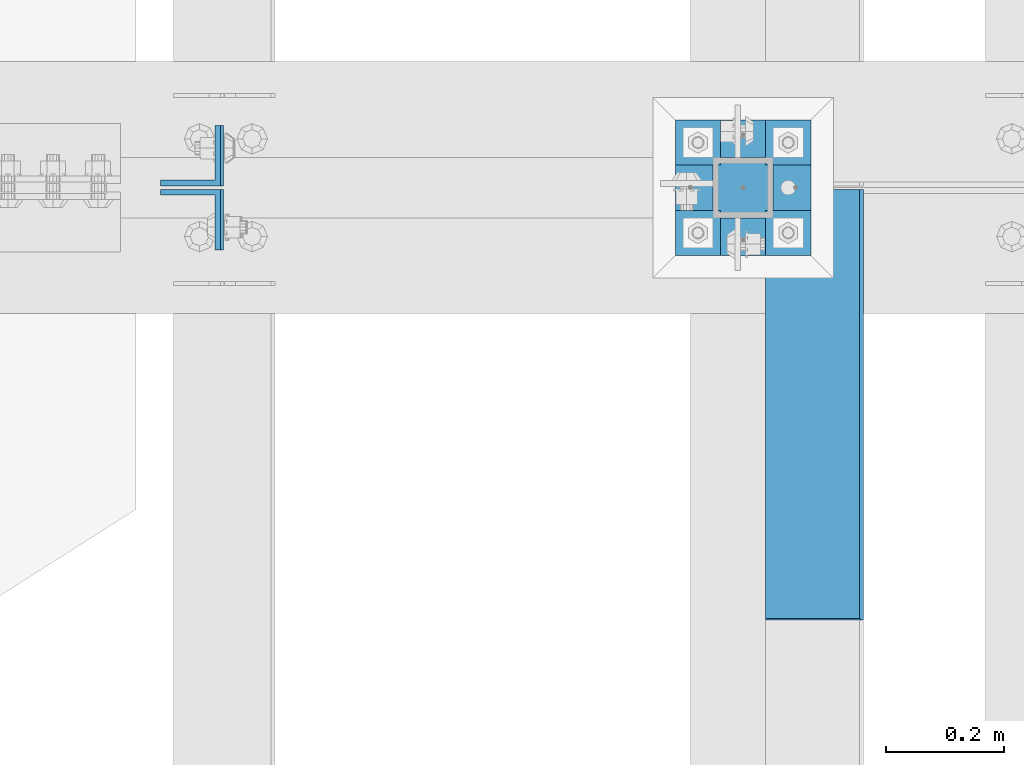
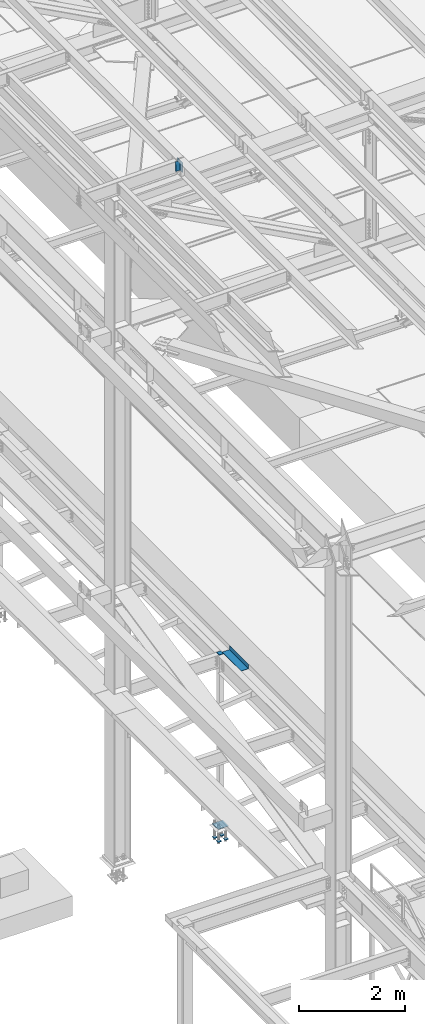
# One storey, part 2185 of 3843: 7 beams, 2 members, 4 elements without a shape of their own.
"""IFC2X3 building model written with IfcOpenShell, lengths in millimetres."""

from ifc_helpers import new_model, si_unit, frame, origin_with_axes, place, context, subcontext, project, spatial, faceted_brep, material, type_object, element, aggregate, save


model = new_model("IFC2X3")

# Units and contexts
model_context = context("Model", 3, precision=1e-05, world=origin_with_axes())
body_context = subcontext(model_context, "Body", "Model", "MODEL_VIEW")
ifc_project = project(units=[si_unit("LENGTHUNIT", "METRE", prefix="MILLI"), si_unit("AREAUNIT", "SQUARE_METRE"), si_unit("VOLUMEUNIT", "CUBIC_METRE"), si_unit("MASSUNIT", "GRAM", prefix="KILO"), si_unit("TIMEUNIT", "SECOND"), si_unit("PLANEANGLEUNIT", "RADIAN"), si_unit("SOLIDANGLEUNIT", "STERADIAN"), si_unit("THERMODYNAMICTEMPERATUREUNIT", "DEGREE_CELSIUS"), si_unit("LUMINOUSINTENSITYUNIT", "LUMEN")], contexts=[model_context])

# Site, building, storey
site_placement = place(None, origin_with_axes())
site = spatial("IfcSite", under=ifc_project, at=site_placement, CompositionType="ELEMENT")
building_placement = place(site_placement, origin_with_axes())
building = spatial("IfcBuilding", under=site, at=building_placement, Name="Undefined", CompositionType="ELEMENT")
storey_placement = place(building_placement, origin_with_axes())
storey = spatial("IfcBuildingStorey", under=building, at=storey_placement, Name="Undefined", CompositionType="ELEMENT", Elevation=0.0)

# Assembly, beam
assembly_1_placement = place(storey_placement, origin_with_axes())
assembly_1 = element("IfcElementAssembly", 1, at=assembly_1_placement, inside=storey, Name="BEAM", AssemblyPlace="NOTDEFINED", PredefinedType="RIGID_FRAME")
ifc_material_1 = material(Name="STEEL/A36")
beam_type_1 = type_object("IfcBeamType", PredefinedType="NOTDEFINED")
beam_1_placement = place(assembly_1_placement, frame((38858.825, 41835.3875, 34039.175), z_axis=(0.0, -1.0, 0.0), x_axis=(1.0, 0.0, 0.0)))
beam_1 = element("IfcBeam", 2, at=beam_1_placement, type_object=beam_type_1, material=ifc_material_1, Name="BENT_PLATE", context=body_context, shape_type="Brep", body=[
    faceted_brep([(161.925005912781, -1.45519152283669e-11, 363.537499999999), (158.749999999993, 3.17500000000291, 360.362499999996), (0.0, 3.17500000000291, 360.362499999996), (0.0, -2.18278728425503e-11, 363.537499999999), (161.924999999996, 98.4249999999956, 363.537499999999), (158.749999999993, 98.4249999999956, 360.362499999996), (165.099999999999, -3.17500000000291, -363.537499999999), (0.0, -3.17500000000291, -363.537499999999), (0.0, 3.17500000000291, -363.537499999999), (158.749999999993, 3.17500000000291, -363.537499999999), (158.749999999993, 98.4249999999956, -363.537499999999), (165.099999999999, 98.4249999999956, -363.537499999999), (165.099999999999, -3.17500000000291, 363.537499999999), (165.099999999999, 98.4249999999956, 363.537499999999), (0.0, -3.17500000000291, 363.53750038147)], [[[0, 1, 2, 3]], [[4, 5, 1, 0]], [[6, 7, 8, 9, 10, 11]], [[12, 6, 11, 13]], [[14, 7, 6, 12]], [[8, 7, 14, 3, 2]], [[9, 8, 2, 1]], [[10, 9, 1, 5]], [[13, 11, 10, 5, 4]], [[14, 12, 13, 4, 0, 3]]]),
])
aggregate(assembly_1, [beam_1])

# Assembly, members
assembly_2_placement = place(storey_placement, origin_with_axes())
assembly_2 = element("IfcElementAssembly", 3, at=assembly_2_placement, inside=storey, Name="BEAM", AssemblyPlace="NOTDEFINED", PredefinedType="RIGID_FRAME")
ifc_material_2 = material(Name="STEEL/A572-50")
member_type = type_object("IfcMemberType", Name="L4X4X3/8", PredefinedType="NOTDEFINED")
member_1_placement = place(assembly_2_placement, frame((37892.6968641246, 42256.0749999523, 45497.6991901238), z_axis=(0.0, 1.0, 0.0), x_axis=(-0.0211520980073474, 0.0, 0.999776269347241)))
member_1 = element("IfcMember", 4, at=member_1_placement, type_object=member_type, material=ifc_material_2, Name="ANGLE", ObjectType="L4X4X3/8", context=body_context, shape_type="Brep", body=[
    faceted_brep([(0.0, 50.8000000000029, -50.8000000000029), (0.0, 50.8000000000029, 50.8000000000029), (228.599999994367, 50.7999999996973, 50.8000000000029), (228.599999994367, 50.7999999996973, -50.8000000000029), (0.0, 41.2750000000015, 50.8000000000029), (228.599999994345, 41.2749999997031, 50.8000000000029), (0.0, 41.2749999999942, -41.2750000000015), (228.599999994345, 41.2749999997031, -41.2750000000015), (0.0, -50.8000000000029, -41.2750000000015), (228.599999994258, -50.8000000001412, -41.2750000000015), (0.0, -50.8000000000029, -50.8000000000029), (228.599999994258, -50.8000000001412, -50.8000000000029)], [[[0, 1, 2, 3]], [[1, 4, 5, 2]], [[4, 6, 7, 5]], [[6, 8, 9, 7]], [[8, 10, 11, 9]], [[10, 0, 3, 11]], [[5, 7, 9, 11, 3, 2]], [[10, 8, 6, 4, 1, 0]]]),
])
member_2_placement = place(assembly_2_placement, frame((37887.8614945193, 42148.1250000477, 45726.2480452912), z_axis=(0.0, -1.0, 0.0), x_axis=(0.0211520550054438, 0.0, -0.999776270257025)))
member_2 = element("IfcMember", 5, at=member_2_placement, type_object=member_type, material=ifc_material_2, Name="ANGLE", ObjectType="L4X4X3/8", context=body_context, shape_type="Brep", body=[
    faceted_brep([(0.0, 50.8000000000029, -50.8000000000029), (0.0, 50.8000000000029, 50.8000000000029), (228.599999994367, 50.7999999996973, 50.8000000000029), (228.599999994367, 50.7999999996973, -50.8000000000029), (0.0, 41.2750000000015, 50.8000000000029), (228.599999994345, 41.2749999997031, 50.8000000000029), (0.0, 41.2749999999942, -41.2750000000015), (228.599999994345, 41.2749999997031, -41.2750000000015), (0.0, -50.8000000000029, -41.2750000000015), (228.599999994258, -50.8000000001412, -41.2750000000015), (0.0, -50.8000000000029, -50.8000000000029), (228.599999994258, -50.8000000001412, -50.8000000000029)], [[[0, 1, 2, 3]], [[1, 4, 5, 2]], [[4, 6, 7, 5]], [[6, 8, 9, 7]], [[8, 10, 11, 9]], [[10, 0, 3, 11]], [[5, 7, 9, 11, 3, 2]], [[10, 8, 6, 4, 1, 0]]]),
])
aggregate(assembly_2, [member_1, member_2])

# Assembly, beam
assembly_3_placement = place(storey_placement, origin_with_axes())
assembly_3 = element("IfcElementAssembly", 6, at=assembly_3_placement, inside=storey, Name="COLUMN", AssemblyPlace="NOTDEFINED", PredefinedType="RIGID_FRAME")
beam_type_2 = type_object("IfcBeamType", PredefinedType="NOTDEFINED")
beam_2_placement = place(assembly_3_placement, frame((38871.525, 42202.1, 34029.65), z_axis=(0.0, 1.0, 0.0), x_axis=(-1.0, 0.0, 0.0)))
beam_2 = element("IfcBeam", 7, at=beam_2_placement, type_object=beam_type_2, material=ifc_material_2, Name="PLATE", context=body_context, shape_type="Brep", body=[
    faceted_brep([(0.0, 6.34999999999854, -50.8000000000029), (0.0, 6.35000000000582, 50.7999992361001), (101.600000000006, 6.34999999999854, 50.8000000000029), (101.600000000006, 6.34999999999854, -50.8000000000029), (0.0, -6.35000000000582, 50.7999992361001), (101.600000000006, -6.34999999999854, 50.8000000000029), (0.0, -6.34999999999854, -50.8000000000029), (101.600000000006, -6.34999999999854, -50.8000000000029)], [[[0, 1, 2, 3]], [[1, 4, 5, 2]], [[4, 6, 7, 5]], [[6, 0, 3, 7]], [[5, 7, 3, 2]], [[6, 4, 1, 0]]]),
])
aggregate(assembly_3, [beam_2])

# Assembly, beams
assembly_4_placement = place(storey_placement, origin_with_axes())
assembly_4 = element("IfcElementAssembly", 8, at=assembly_4_placement, inside=storey, Name="TEMPLATE", AssemblyPlace="NOTDEFINED", PredefinedType="RIGID_FRAME")
beam_type_3 = type_object("IfcBeamType", PredefinedType="NOTDEFINED")
beam_3_placement = place(assembly_4_placement, frame((38935.025, 42125.9, 29762.45), z_axis=(0.0, 1.0, 0.0), x_axis=(-1.0, 0.0, 0.0)))
beam_3 = element("IfcBeam", 9, at=beam_3_placement, type_object=beam_type_3, material=ifc_material_2, context=body_context, shape_type="Brep", body=[
    faceted_brep([(0.0, 6.34999999999854, -38.1000000000058), (0.0, 6.34999999999854, 38.0999984741211), (76.1999999999971, 6.34999999999854, 38.1000000000058), (76.1999999999971, 6.34999999999854, -38.1000000000058), (0.0, -6.34999999999854, 38.0999984741211), (76.1999999999971, -6.34999999999854, 38.1000000000058), (0.0, -6.34999999999854, -38.1000000000058), (76.1999999999971, -6.34999999999854, -38.1000000000058)], [[[0, 1, 2, 3]], [[1, 4, 5, 2]], [[4, 6, 7, 5]], [[6, 0, 3, 7]], [[5, 7, 3, 2]], [[6, 4, 1, 0]]]),
])
beam_4_placement = place(assembly_4_placement, frame((38935.025, 42278.3, 29762.45), z_axis=(0.0, 1.0, 0.0), x_axis=(-1.0, 0.0, 0.0)))
beam_4 = element("IfcBeam", 10, at=beam_4_placement, type_object=beam_type_3, material=ifc_material_2, context=body_context, shape_type="Brep", body=[
    faceted_brep([(0.0, 6.34999999999854, -38.1000000000058), (0.0, 6.34999999999854, 38.0999984741211), (76.1999999999971, 6.34999999999854, 38.1000000000058), (76.1999999999971, 6.34999999999854, -38.1000000000058), (0.0, -6.34999999999854, 38.0999984741211), (76.1999999999971, -6.34999999999854, 38.1000000000058), (0.0, -6.34999999999854, -38.1000000000058), (76.1999999999971, -6.34999999999854, -38.1000000000058)], [[[0, 1, 2, 3]], [[1, 4, 5, 2]], [[4, 6, 7, 5]], [[6, 0, 3, 7]], [[5, 7, 3, 2]], [[6, 4, 1, 0]]]),
])
beam_5_placement = place(assembly_4_placement, frame((38782.625, 42125.9, 29762.45), z_axis=(0.0, 1.0, 0.0), x_axis=(-1.0, 0.0, 0.0)))
beam_5 = element("IfcBeam", 11, at=beam_5_placement, type_object=beam_type_3, material=ifc_material_2, context=body_context, shape_type="Brep", body=[
    faceted_brep([(0.0, 6.34999999999854, -38.1000000000058), (0.0, 6.34999999999854, 38.0999984741211), (76.1999999999971, 6.34999999999854, 38.1000000000058), (76.1999999999971, 6.34999999999854, -38.1000000000058), (0.0, -6.34999999999854, 38.0999984741211), (76.1999999999971, -6.34999999999854, 38.1000000000058), (0.0, -6.34999999999854, -38.1000000000058), (76.1999999999971, -6.34999999999854, -38.1000000000058)], [[[0, 1, 2, 3]], [[1, 4, 5, 2]], [[4, 6, 7, 5]], [[6, 0, 3, 7]], [[5, 7, 3, 2]], [[6, 4, 1, 0]]]),
])
beam_6_placement = place(assembly_4_placement, frame((38782.625, 42278.3, 29762.45), z_axis=(0.0, 1.0, 0.0), x_axis=(-1.0, 0.0, 0.0)))
beam_6 = element("IfcBeam", 12, at=beam_6_placement, type_object=beam_type_3, material=ifc_material_2, context=body_context, shape_type="Brep", body=[
    faceted_brep([(0.0, 6.34999999999854, -38.1000000000058), (0.0, 6.34999999999854, 38.0999984741211), (76.1999999999971, 6.34999999999854, 38.1000000000058), (76.1999999999971, 6.34999999999854, -38.1000000000058), (0.0, -6.34999999999854, 38.0999984741211), (76.1999999999971, -6.34999999999854, 38.1000000000058), (0.0, -6.34999999999854, -38.1000000000058), (76.1999999999971, -6.34999999999854, -38.1000000000058)], [[[0, 1, 2, 3]], [[1, 4, 5, 2]], [[4, 6, 7, 5]], [[6, 0, 3, 7]], [[5, 7, 3, 2]], [[6, 4, 1, 0]]]),
])
beam_type_4 = type_object("IfcBeamType", PredefinedType="NOTDEFINED")
beam_7_placement = place(assembly_4_placement, frame((38935.025, 42202.1, 30062.4875), z_axis=(0.0, -1.0, 0.0), x_axis=(-1.0, 0.0, 0.0)))
beam_7 = element("IfcBeam", 13, at=beam_7_placement, type_object=beam_type_4, material=ifc_material_2, Name="TEMPLATE", context=body_context, shape_type="Brep", body=[
    faceted_brep([(0.0, 1.58750000000146, -114.300000000003), (0.0, 1.58750000000146, 114.300000000003), (228.600000000006, 1.58750000000146, 114.300000000003), (228.600000000006, 1.58750000000146, -114.300000000003), (0.0, -1.58750000000146, 114.300000000003), (228.600000000006, -1.58750000000146, 114.300000000003), (0.0, -1.58750000000146, -114.300000000003), (228.600000000006, -1.58750000000146, -114.300000000003)], [[[0, 1, 2, 3]], [[1, 4, 5, 2]], [[4, 6, 7, 5]], [[6, 0, 3, 7]], [[5, 7, 3, 2]], [[6, 4, 1, 0]]]),
])
aggregate(assembly_4, [beam_3, beam_4, beam_5, beam_6, beam_7])

save(model, "model.ifc")
